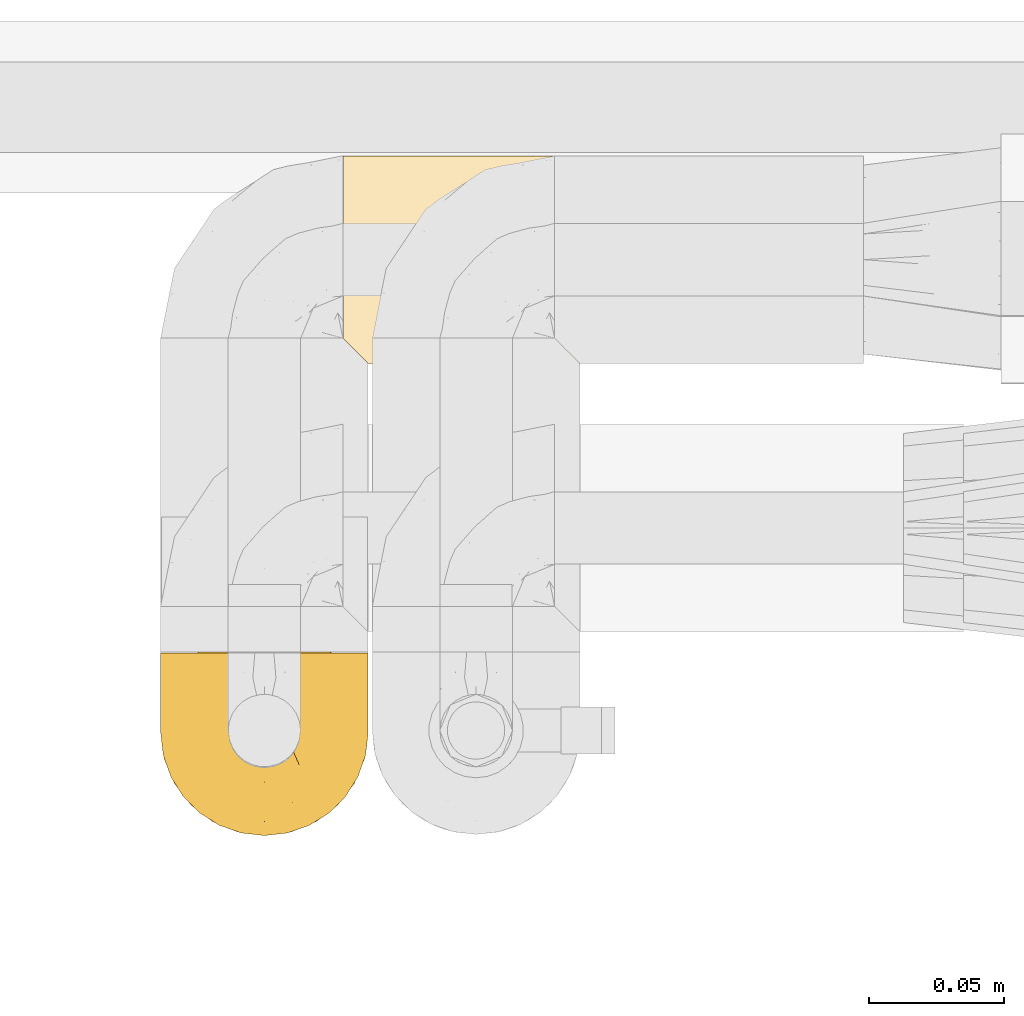
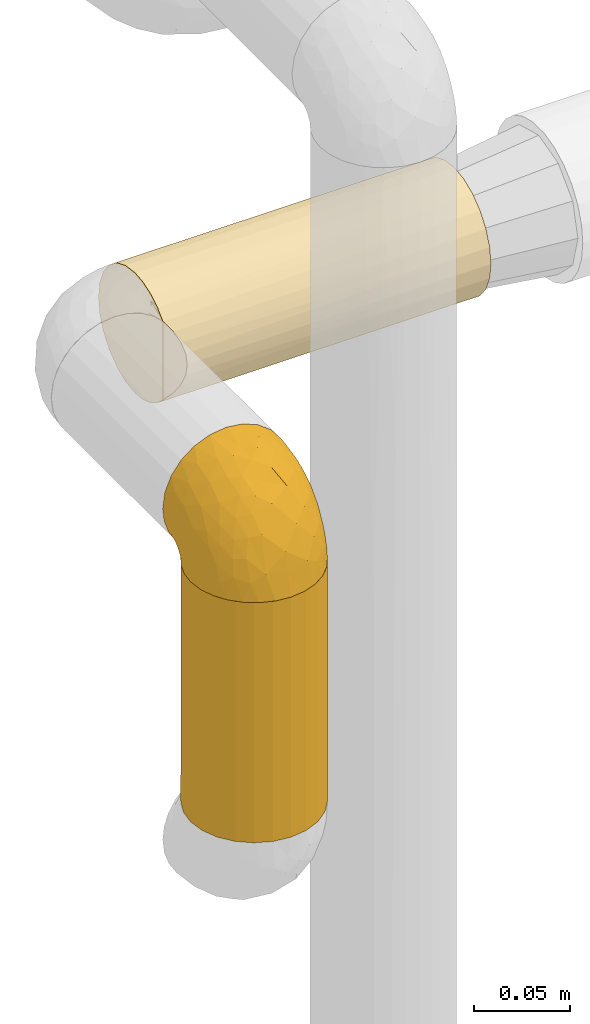
# One storey, part 469 of 827: 3 coverings.
"""IFC2X3 building model written with IfcOpenShell, lengths in millimetres."""

from ifc_helpers import new_model, entity, si_unit, converted_unit, derived_unit, direction, frame, origin, place, context, subcontext, project, spatial, faceted_brep, element, save


model = new_model("IFC2X3")

# Units and contexts
model_context = context("Model", 3, precision=0.01, world=origin(), true_north=direction((6.12303176911189e-17, 1.0)))
body_context = subcontext(model_context, "Body", "Model", "MODEL_VIEW")
ifc_project = project(units=[si_unit("LENGTHUNIT", "METRE", prefix="MILLI"), si_unit("AREAUNIT", "SQUARE_METRE"), si_unit("VOLUMEUNIT", "CUBIC_METRE"), converted_unit("PLANEANGLEUNIT", "DEGREE", entity("IfcRatioMeasure", 0.0174532925199433), si_unit("PLANEANGLEUNIT", "RADIAN"), dimensions=[0, 0, 0, 0, 0, 0, 0]), si_unit("MASSUNIT", "GRAM", prefix="KILO"), derived_unit("MASSDENSITYUNIT", [(si_unit("MASSUNIT", "GRAM", prefix="KILO"), 1), (si_unit("LENGTHUNIT", "METRE"), -3)]), derived_unit("MOMENTOFINERTIAUNIT", [(si_unit("LENGTHUNIT", "METRE"), 4)]), si_unit("TIMEUNIT", "SECOND"), si_unit("FREQUENCYUNIT", "HERTZ"), si_unit("THERMODYNAMICTEMPERATUREUNIT", "DEGREE_CELSIUS"), derived_unit("THERMALTRANSMITTANCEUNIT", [(si_unit("MASSUNIT", "GRAM", prefix="KILO"), 1), (si_unit("THERMODYNAMICTEMPERATUREUNIT", "KELVIN"), -1), (si_unit("TIMEUNIT", "SECOND"), -3)]), derived_unit("VOLUMETRICFLOWRATEUNIT", [(si_unit("LENGTHUNIT", "METRE"), 3), (si_unit("TIMEUNIT", "SECOND"), -1)]), derived_unit("MASSFLOWRATEUNIT", [(si_unit("MASSUNIT", "GRAM", prefix="KILO"), 1), (si_unit("TIMEUNIT", "SECOND"), -1)]), derived_unit("ROTATIONALFREQUENCYUNIT", [(si_unit("TIMEUNIT", "SECOND"), -1)]), si_unit("ELECTRICCURRENTUNIT", "AMPERE"), si_unit("ELECTRICVOLTAGEUNIT", "VOLT"), si_unit("POWERUNIT", "WATT"), si_unit("FORCEUNIT", "NEWTON", prefix="KILO"), si_unit("ILLUMINANCEUNIT", "LUX"), si_unit("LUMINOUSFLUXUNIT", "LUMEN"), si_unit("LUMINOUSINTENSITYUNIT", "CANDELA"), derived_unit("USERDEFINED", [(si_unit("MASSUNIT", "GRAM", prefix="KILO"), -1), (si_unit("LENGTHUNIT", "METRE"), -2), (si_unit("TIMEUNIT", "SECOND"), 3), (si_unit("LUMINOUSFLUXUNIT", "LUMEN"), 1)]), derived_unit("LINEARVELOCITYUNIT", [(si_unit("LENGTHUNIT", "METRE"), 1), (si_unit("TIMEUNIT", "SECOND"), -1)]), si_unit("PRESSUREUNIT", "PASCAL"), derived_unit("USERDEFINED", [(si_unit("LENGTHUNIT", "METRE"), -2), (si_unit("MASSUNIT", "GRAM", prefix="KILO"), 1), (si_unit("TIMEUNIT", "SECOND"), -2)]), derived_unit("LINEARFORCEUNIT", [(si_unit("MASSUNIT", "GRAM", prefix="KILO"), 1), (si_unit("LENGTHUNIT", "METRE"), 1), (si_unit("TIMEUNIT", "SECOND"), -2), (si_unit("LENGTHUNIT", "METRE"), -1)]), derived_unit("PLANARFORCEUNIT", [(si_unit("MASSUNIT", "GRAM", prefix="KILO"), 1), (si_unit("LENGTHUNIT", "METRE"), 1), (si_unit("TIMEUNIT", "SECOND"), -2), (si_unit("LENGTHUNIT", "METRE"), -2)])], contexts=[model_context])

# Site, building, storey
site_placement = place(None, origin())
site = spatial("IfcSite", under=ifc_project, at=site_placement, CompositionType="ELEMENT")
building_placement = place(site_placement, origin())
building = spatial("IfcBuilding", under=site, at=building_placement, CompositionType="ELEMENT")
storey_placement = place(building_placement, frame((0.0, 0.0, 28200.0)))
storey = spatial("IfcBuildingStorey", under=building, at=storey_placement, Name="08", CompositionType="ELEMENT", Elevation=28200.0)

# Coverings
covering_1_placement = place(storey_placement, frame((58451.15, 16264.34, 969.3)))
element("IfcCovering", 1, at=covering_1_placement, inside=storey, Name=":ADSK_", ObjectType=":ADSK_", PredefinedType="INSULATION", context=body_context, shape_type="Brep", body=[
    faceted_brep([(74.68, 23.36, 1.6), (70.1, 16.07, 1.6), (64.01, 9.98, 1.6), (56.72, 5.4, 1.6), (48.6, 2.56, 1.6), (40.05, 1.6, 1.6), (31.49, 2.56, 1.6), (23.36, 5.41, 1.6), (16.07, 9.99, 1.6), (9.98, 16.08, 1.6), (5.4, 23.37, 1.6), (2.56, 31.49, 1.6), (1.6, 40.05, 1.6), (2.46, 48.15, 1.6), (5.01, 55.88, 1.6), (9.13, 62.9, 1.6), (14.62, 68.89, 1.6), (16.82, 68.89, 1.6), (18.56, 68.89, 1.6), (20.52, 68.89, 1.6), (22.49, 68.89, 1.6), (24.46, 68.89, 1.6), (26.42, 68.89, 1.6), (28.39, 68.89, 1.6), (30.36, 68.89, 1.6), (32.55, 68.89, 1.6), (34.75, 68.89, 1.6), (36.94, 68.89, 1.6), (39.13, 68.89, 1.6), (41.33, 68.89, 1.6), (43.52, 68.89, 1.6), (45.72, 68.89, 1.6), (47.91, 68.89, 1.6), (50.11, 68.89, 1.6), (52.3, 68.89, 1.6), (54.49, 68.89, 1.6), (56.69, 68.89, 1.6), (58.88, 68.89, 1.6), (61.08, 68.89, 1.6), (63.27, 68.89, 1.6), (65.47, 68.89, 1.6), (70.97, 62.89, 1.6), (75.09, 55.86, 1.6), (77.64, 48.13, 1.6), (78.5, 40.05, 1.6), (77.53, 31.49, 1.6), (14.62, 69.15, 1.85), (9.12, 69.15, 7.85), (5.0, 69.15, 14.87), (2.46, 69.15, 22.6), (1.6, 69.15, 30.7), (2.91, 69.15, 40.65), (6.75, 69.15, 49.92), (12.86, 69.15, 57.88), (20.82, 69.15, 63.99), (30.09, 69.15, 67.84), (40.05, 69.15, 69.15), (50.0, 69.15, 67.84), (59.27, 69.15, 63.99), (67.23, 69.15, 57.88), (73.34, 69.15, 49.92), (77.19, 69.15, 40.65), (78.5, 69.15, 30.7), (77.63, 69.15, 22.6), (75.09, 69.15, 14.87), (70.97, 69.15, 7.85), (65.47, 69.15, 1.85), (63.27, 69.15, 1.85), (62.29, 69.15, 1.85), (60.7, 69.15, 1.85), (59.11, 69.15, 1.85), (57.52, 69.15, 1.85), (55.93, 69.15, 1.85), (54.34, 69.15, 1.85), (52.76, 69.15, 1.85), (51.17, 69.15, 1.85), (49.58, 69.15, 1.85), (47.99, 69.15, 1.85), (46.4, 69.15, 1.85), (44.81, 69.15, 1.85), (43.22, 69.15, 1.85), (41.63, 69.15, 1.85), (40.05, 69.15, 1.85), (38.46, 69.15, 1.85), (36.87, 69.15, 1.85), (35.28, 69.15, 1.85), (33.69, 69.15, 1.85), (32.1, 69.15, 1.85), (30.51, 69.15, 1.85), (28.92, 69.15, 1.85), (27.33, 69.15, 1.85), (25.37, 69.15, 1.85), (23.4, 69.15, 1.85), (21.21, 69.15, 1.85), (19.01, 69.15, 1.85), (16.82, 69.15, 1.85), (42.32, 68.96, 1.77), (44.02, 68.97, 1.78), (47.13, 68.97, 1.77), (48.74, 68.97, 1.77), (23.57, 68.95, 1.76), (25.13, 68.96, 1.77), (61.34, 68.98, 1.79), (22.02, 68.97, 1.78), (29.72, 68.97, 1.78), (56.73, 68.98, 1.78), (55.14, 68.97, 1.78), (37.66, 68.97, 1.78), (64.12, 68.94, 1.74), (28.13, 68.98, 1.78), (26.62, 68.98, 1.78), (31.46, 68.96, 1.77), (16.16, 68.97, 1.78), (39.16, 68.98, 1.78), (50.37, 68.98, 1.78), (17.69, 68.97, 1.77), (19.17, 68.96, 1.77), (62.78, 68.97, 1.77), (58.35, 68.97, 1.78), (45.53, 68.98, 1.78), (59.91, 68.96, 1.77), (65.47, 68.97, 1.77), (65.47, 68.94, 1.72), (65.47, 68.92, 1.66), (14.62, 68.97, 1.77), (14.62, 69.02, 1.8), (14.62, 69.08, 1.82), (20.59, 68.98, 1.79), (32.99, 68.97, 1.78), (34.48, 68.98, 1.79), (51.91, 68.97, 1.78), (65.47, 69.08, 1.82), (65.47, 69.02, 1.8), (53.48, 68.96, 1.76), (14.62, 68.92, 1.66), (14.62, 68.94, 1.72), (40.77, 68.97, 1.78), (35.97, 68.96, 1.77), (7.84, 67.02, 9.41), (3.53, 63.33, 17.65), (8.32, 64.61, 7.41), (1.6, 49.27, 21.47), (2.19, 51.4, 15.21), (1.6, 43.94, 16.15), (1.6, 61.87, 28.75), (4.57, 61.54, 13.67), (3.96, 57.95, 12.79), (2.28, 56.12, 19.18), (1.6, 63.4, 29.16), (7.69, 65.41, 9.04), (3.53, 53.1, 7.41), (8.32, 63.04, 5.74), (7.84, 61.33, 3.72), (1.6, 41.99, 8.87), (1.6, 54.6, 26.8), (4.34, 56.6, 9.53), (1.6, 41.58, 7.34), (29.63, 13.72, 37.63), (27.34, 5.82, 17.92), (40.05, 6.74, 27.45), (2.39, 58.82, 37.01), (2.43, 51.58, 34.22), (9.07, 42.09, 45.87), (16.64, 46.12, 56.57), (9.54, 55.56, 52.31), (4.52, 52.38, 42.07), (4.52, 61.54, 44.74), (7.49, 23.76, 21.49), (7.49, 20.5, 11.02), (12.85, 14.64, 15.64), (2.35, 41.77, 26.02), (22.66, 16.28, 36.59), (32.9, 49.4, 65.49), (25.33, 52.34, 63.99), (40.05, 4.3, 15.2), (16.64, 58.67, 60.27), (19.99, 25.26, 45.25), (16.37, 20.17, 35.21), (3.26, 34.7, 22.52), (3.75, 28.67, 12.03), (19.58, 8.62, 13.32), (7.5, 33.37, 35.9), (4.04, 41.35, 33.87), (13.94, 17.15, 25.73), (19.58, 12.68, 26.34), (28.21, 21.47, 46.78), (24.75, 41.11, 59.54), (31.42, 37.53, 60.18), (26.2, 30.64, 53.93), (33.36, 26.66, 53.36), (40.05, 21.38, 49.36), (40.05, 14.06, 38.4), (40.05, 55.54, 66.44), (16.14, 35.17, 50.09), (12.85, 29.04, 41.08), (10.47, 24.34, 31.14), (6.49, 29.33, 28.19), (40.05, 43.3, 64.0), (40.05, 32.34, 56.68), (75.57, 57.75, 43.9), (47.37, 49.41, 65.46), (52.91, 27.85, 52.22), (50.46, 13.7, 37.61), (67.23, 14.63, 15.64), (60.5, 8.61, 13.31), (70.55, 48.85, 50.02), (63.45, 54.13, 59.28), (62.61, 37.84, 53.05), (72.6, 23.75, 21.48), (72.6, 20.49, 11.01), (76.34, 28.66, 12.03), (59.34, 20.83, 41.02), (77.76, 55.15, 35.39), (78.5, 54.6, 26.8), (78.5, 61.87, 28.75), (78.5, 41.58, 7.34), (53.16, 57.58, 65.81), (70.55, 59.91, 53.28), (48.88, 36.94, 59.8), (54.76, 45.72, 61.82), (52.74, 5.82, 17.91), (71.93, 37.91, 41.4), (75.79, 50.18, 40.48), (60.5, 12.67, 26.34), (77.86, 49.29, 31.68), (77.64, 42.64, 27.68), (78.5, 43.94, 16.15), (78.5, 49.27, 21.47), (67.23, 19.45, 28.05), (76.82, 34.7, 22.54), (78.5, 41.99, 8.87), (77.8, 62.29, 37.3), (67.23, 29.01, 41.07), (73.2, 31.47, 32.24), (67.66, 37.18, 47.4), (75.99, 43.45, 35.77), (76.57, 63.33, 17.65), (73.21, 67.23, 11.06), (71.93, 66.07, 8.55), (71.07, 65.22, 6.63), (75.09, 61.99, 12.77), (76.13, 57.95, 12.79), (76.57, 53.09, 7.41), (77.69, 56.84, 18.97), (72.26, 61.33, 3.72), (71.77, 63.06, 5.76), (77.9, 51.41, 15.21), (75.75, 56.61, 9.52)], [[[0, 1, 2, 3, 4, 5, 6, 7, 8, 9, 10, 11, 12, 13, 14, 15, 16, 17, 18, 19, 20, 21, 22, 23, 24, 25, 26, 27, 28, 29, 30, 31, 32, 33, 34, 35, 36, 37, 38, 39, 40, 41, 42, 43, 44, 45]], [[46, 47, 48, 49, 50, 51, 52, 53, 54, 55, 56, 57, 58, 59, 60, 61, 62, 63, 64, 65, 66, 67, 68, 69, 70, 71, 72, 73, 74, 75, 76, 77, 78, 79, 80, 81, 82, 83, 84, 85, 86, 87, 88, 89, 90, 91, 92, 93, 94, 95]], [[96, 97, 30]], [[98, 77, 99]], [[100, 101, 21]], [[69, 68, 102]], [[20, 19, 103]], [[24, 23, 104]], [[20, 103, 100]], [[72, 105, 106]], [[84, 83, 107]], [[89, 88, 104]], [[108, 67, 66]], [[109, 110, 90]], [[111, 25, 24]], [[112, 17, 16]], [[82, 113, 83]], [[109, 23, 22]], [[114, 76, 75]], [[105, 36, 106]], [[104, 111, 24]], [[18, 115, 116]], [[97, 96, 80]], [[67, 108, 117]], [[105, 71, 118]], [[31, 97, 119]], [[102, 120, 69]], [[108, 121, 122, 123, 40]], [[112, 95, 115]], [[17, 115, 18]], [[94, 116, 115]], [[117, 68, 67]], [[38, 117, 39]], [[112, 124, 125, 126, 46]], [[17, 112, 115]], [[70, 120, 118]], [[39, 117, 108]], [[120, 38, 37]], [[120, 37, 118]], [[120, 70, 69]], [[116, 94, 127]], [[128, 86, 129]], [[117, 38, 102]], [[74, 130, 75]], [[99, 33, 32]], [[115, 95, 94]], [[39, 108, 40]], [[108, 66, 131, 132, 121]], [[105, 72, 71]], [[118, 37, 36]], [[71, 70, 118]], [[35, 106, 36]], [[36, 105, 118]], [[35, 133, 106]], [[74, 73, 133]], [[106, 133, 73]], [[99, 114, 33]], [[133, 35, 34]], [[73, 72, 106]], [[95, 112, 46]], [[112, 16, 134, 135, 124]], [[130, 114, 75]], [[99, 76, 114]], [[114, 130, 33]], [[34, 33, 130]], [[78, 77, 98]], [[98, 119, 78]], [[130, 133, 34]], [[133, 130, 74]], [[79, 97, 80]], [[98, 99, 32]], [[98, 32, 31]], [[77, 76, 99]], [[97, 79, 119]], [[136, 96, 29]], [[30, 97, 31]], [[136, 29, 28]], [[81, 80, 96]], [[29, 96, 30]], [[31, 119, 98]], [[119, 79, 78]], [[96, 136, 81]], [[82, 81, 136]], [[113, 107, 83]], [[84, 107, 137]], [[107, 27, 137]], [[113, 28, 107]], [[27, 107, 28]], [[85, 84, 137]], [[137, 27, 26]], [[113, 136, 28]], [[136, 113, 82]], [[109, 89, 104]], [[86, 85, 129]], [[89, 109, 90]], [[111, 87, 128]], [[26, 129, 137]], [[88, 111, 104]], [[25, 111, 128]], [[22, 110, 109]], [[23, 109, 104]], [[110, 91, 90]], [[100, 92, 101]], [[110, 22, 101]], [[91, 110, 101]], [[116, 19, 18]], [[111, 88, 87]], [[127, 103, 19]], [[25, 128, 26]], [[86, 128, 87]], [[128, 129, 26]], [[137, 129, 85]], [[120, 102, 38]], [[117, 102, 68]], [[91, 101, 92]], [[21, 101, 22]], [[93, 92, 103]], [[100, 21, 20]], [[100, 103, 92]], [[127, 93, 103]], [[93, 127, 94]], [[116, 127, 19]], [[126, 138, 47]], [[48, 138, 139]], [[140, 125, 124]], [[141, 142, 143]], [[144, 49, 139]], [[145, 140, 146]], [[48, 139, 49]], [[139, 145, 147]], [[49, 144, 148, 50]], [[126, 125, 149]], [[14, 13, 150]], [[151, 146, 140]], [[149, 140, 145]], [[152, 151, 135]], [[152, 14, 150]], [[16, 15, 134]], [[13, 153, 150]], [[124, 151, 140]], [[141, 147, 142]], [[14, 152, 15]], [[15, 152, 134]], [[47, 46, 126]], [[139, 154, 144]], [[138, 48, 47]], [[125, 140, 149]], [[135, 134, 152]], [[146, 155, 142]], [[145, 146, 147]], [[149, 139, 138]], [[147, 141, 154]], [[147, 146, 142]], [[139, 147, 154]], [[139, 149, 145]], [[149, 138, 126]], [[155, 146, 151]], [[150, 143, 142]], [[152, 155, 151]], [[150, 142, 155]], [[13, 12, 156, 153]], [[153, 143, 150]], [[152, 150, 155]], [[151, 124, 135]], [[157, 158, 159]], [[160, 154, 161]], [[162, 163, 164]], [[165, 166, 160]], [[167, 168, 169]], [[141, 170, 161]], [[156, 12, 11]], [[158, 157, 171]], [[172, 55, 173]], [[158, 6, 174]], [[175, 54, 53]], [[52, 166, 164]], [[52, 164, 53]], [[54, 175, 173]], [[166, 52, 51]], [[176, 177, 171]], [[178, 143, 179]], [[156, 11, 179]], [[8, 7, 180]], [[169, 9, 8]], [[179, 143, 153, 156]], [[179, 11, 10]], [[168, 179, 10]], [[181, 162, 182]], [[179, 167, 178]], [[183, 184, 177]], [[183, 169, 184]], [[176, 171, 185]], [[172, 186, 187]], [[158, 7, 6]], [[159, 158, 174]], [[184, 180, 158]], [[54, 173, 55]], [[180, 169, 8]], [[188, 189, 187]], [[9, 168, 10]], [[186, 188, 187]], [[190, 157, 159, 191]], [[55, 172, 192]], [[176, 193, 194]], [[161, 170, 182]], [[162, 164, 165]], [[175, 164, 163]], [[51, 50, 148]], [[167, 195, 196]], [[178, 182, 170]], [[6, 5, 174]], [[158, 180, 7]], [[169, 180, 184]], [[169, 168, 9]], [[179, 168, 167]], [[182, 162, 165]], [[162, 194, 193]], [[161, 165, 160]], [[195, 181, 196]], [[192, 172, 197]], [[192, 56, 55]], [[189, 190, 198]], [[198, 197, 187]], [[172, 187, 197]], [[185, 189, 188]], [[198, 187, 189]], [[186, 172, 173]], [[173, 163, 186]], [[193, 186, 163]], [[176, 185, 188]], [[185, 157, 190]], [[188, 186, 193]], [[177, 176, 194]], [[188, 193, 176]], [[162, 193, 163]], [[195, 177, 194]], [[171, 177, 184]], [[181, 195, 194]], [[183, 167, 169]], [[162, 181, 194]], [[196, 182, 178]], [[158, 171, 184]], [[171, 157, 185]], [[177, 195, 183]], [[167, 183, 195]], [[182, 196, 181]], [[178, 170, 143]], [[178, 167, 196]], [[164, 175, 53]], [[173, 175, 163]], [[160, 51, 148]], [[164, 166, 165]], [[51, 160, 166]], [[160, 148, 144, 154]], [[141, 161, 154]], [[182, 165, 161]], [[190, 189, 185]], [[143, 170, 141]], [[60, 199, 61]], [[197, 200, 192]], [[201, 190, 202]], [[200, 57, 192]], [[203, 204, 2]], [[205, 206, 207]], [[208, 209, 210]], [[211, 207, 201]], [[212, 213, 214]], [[45, 215, 210]], [[216, 206, 58]], [[45, 44, 215]], [[59, 217, 60]], [[60, 217, 199]], [[0, 45, 210]], [[218, 201, 219]], [[202, 159, 220]], [[205, 221, 222]], [[223, 204, 203]], [[1, 203, 2]], [[57, 200, 216]], [[220, 3, 204]], [[220, 174, 4]], [[1, 0, 209]], [[212, 224, 213]], [[225, 226, 227]], [[228, 223, 203]], [[208, 210, 229]], [[210, 226, 229]], [[3, 220, 4]], [[58, 206, 59]], [[209, 203, 1]], [[202, 220, 223]], [[228, 203, 208]], [[202, 211, 201]], [[3, 2, 204]], [[202, 190, 191, 159]], [[210, 215, 230, 226]], [[199, 212, 231]], [[232, 233, 221]], [[233, 208, 229]], [[207, 206, 219]], [[217, 206, 205]], [[227, 224, 225]], [[233, 232, 228]], [[201, 207, 219]], [[234, 232, 221]], [[218, 219, 200]], [[202, 223, 211]], [[174, 220, 159]], [[174, 5, 4]], [[61, 231, 62]], [[220, 204, 223]], [[210, 209, 0]], [[203, 209, 208]], [[225, 233, 229]], [[224, 227, 213]], [[221, 233, 235]], [[57, 56, 192]], [[198, 218, 197]], [[200, 219, 216]], [[201, 198, 190]], [[197, 218, 200]], [[198, 201, 218]], [[206, 216, 219]], [[58, 57, 216]], [[231, 212, 214]], [[222, 212, 199]], [[228, 211, 223]], [[207, 211, 232]], [[62, 231, 214]], [[199, 231, 61]], [[233, 228, 208]], [[211, 228, 232]], [[222, 221, 235]], [[234, 205, 207]], [[206, 217, 59]], [[199, 217, 205]], [[205, 222, 199]], [[224, 222, 235]], [[222, 224, 212]], [[224, 235, 225]], [[233, 225, 235]], [[226, 225, 229]], [[205, 234, 221]], [[207, 232, 234]], [[63, 214, 236]], [[214, 213, 236]], [[214, 63, 62]], [[237, 236, 238]], [[238, 132, 131]], [[236, 237, 64]], [[239, 240, 241]], [[63, 236, 64]], [[131, 66, 65]], [[237, 131, 65]], [[242, 230, 43]], [[237, 65, 64]], [[239, 121, 132]], [[42, 242, 43]], [[241, 240, 243]], [[41, 123, 244]], [[43, 230, 215, 44]], [[244, 122, 245]], [[227, 246, 243]], [[241, 247, 245]], [[121, 239, 245]], [[41, 40, 123]], [[132, 238, 239]], [[244, 42, 41]], [[131, 237, 238]], [[240, 239, 238]], [[245, 239, 241]], [[247, 241, 246]], [[247, 244, 245]], [[238, 236, 240]], [[243, 236, 213]], [[236, 243, 240]], [[227, 226, 246]], [[243, 213, 227]], [[242, 246, 226]], [[243, 246, 241]], [[246, 242, 247]], [[244, 247, 242]], [[242, 226, 230]], [[42, 244, 242]], [[122, 244, 123]], [[122, 121, 245]]]),
])
covering_2_placement = place(storey_placement, frame((58451.2, 16264.39, 817.55)))
element("IfcCovering", 2, at=covering_2_placement, inside=storey, Name=":ADSK_", ObjectType=":ADSK_", PredefinedType="INSULATION", context=body_context, shape_type="Brep", body=[
    faceted_brep([(73.25, 20.8, 153.35), (77.09, 30.06, 153.35), (78.4, 40.0, 153.35), (77.51, 48.2, 153.35), (74.9, 56.01, 153.35), (70.68, 63.08, 153.35), (65.05, 69.1, 153.35), (14.94, 69.1, 153.35), (9.31, 63.08, 153.35), (5.09, 56.01, 153.35), (2.48, 48.2, 153.35), (1.6, 40.0, 153.35), (2.9, 30.06, 153.35), (6.74, 20.8, 153.35), (12.84, 12.84, 153.35), (20.8, 6.74, 153.35), (30.06, 2.9, 153.35), (40.0, 1.6, 153.35), (49.93, 2.9, 153.35), (59.2, 6.74, 153.35), (67.15, 12.84, 153.35), (73.25, 20.8, 0.0), (67.15, 12.84, 0.0), (59.2, 6.74, 0.0), (49.93, 2.9, 0.0), (40.0, 1.6, 0.0), (30.06, 2.9, 0.0), (20.8, 6.74, 0.0), (12.84, 12.84, 0.0), (6.74, 20.8, 0.0), (2.9, 30.06, 0.0), (1.6, 40.0, 0.0), (2.9, 49.93, 0.0), (6.74, 59.2, 0.0), (12.84, 67.15, 0.0), (20.8, 73.25, 0.0), (30.06, 77.09, 0.0), (40.0, 78.4, 0.0), (49.93, 77.09, 0.0), (59.2, 73.25, 0.0), (67.15, 67.15, 0.0), (73.25, 59.2, 0.0), (77.09, 49.93, 0.0), (78.4, 40.0, 0.0), (77.09, 30.06, 0.0), (33.21, 77.79, 144.65), (40.0, 78.4, 144.05), (26.63, 76.0, 146.45), (20.48, 73.07, 149.37), (53.36, 76.0, 146.45), (46.78, 77.79, 144.65), (59.51, 73.07, 149.37)], [[[0, 1, 2, 3, 4, 5, 6, 7, 8, 9, 10, 11, 12, 13, 14, 15, 16, 17, 18, 19, 20]], [[21, 22, 23, 24, 25, 26, 27, 28, 29, 30, 31, 32, 33, 34, 35, 36, 37, 38, 39, 40, 41, 42, 43, 44]], [[45, 46, 37]], [[45, 37, 36]], [[47, 36, 35]], [[47, 45, 36]], [[7, 48, 35]], [[47, 35, 48]], [[35, 34, 7]], [[8, 34, 33]], [[9, 33, 32]], [[10, 32, 31]], [[8, 33, 9]], [[9, 32, 10]], [[31, 11, 10]], [[34, 8, 7]], [[12, 11, 31, 30]], [[13, 12, 30, 29]], [[29, 28, 14, 13]], [[16, 15, 27, 26]], [[17, 16, 26, 25]], [[28, 27, 15, 14]], [[18, 17, 25, 24]], [[19, 18, 24, 23]], [[23, 22, 20, 19]], [[1, 0, 21, 44]], [[2, 1, 44, 43]], [[22, 21, 0, 20]], [[3, 43, 42]], [[4, 42, 41]], [[5, 41, 40]], [[2, 43, 3]], [[3, 42, 4]], [[41, 5, 4]], [[40, 6, 5]], [[49, 39, 38]], [[38, 37, 50]], [[46, 50, 37]], [[51, 6, 39]], [[50, 49, 38]], [[51, 39, 49]], [[39, 6, 40]], [[49, 50, 46, 45, 47, 48, 7, 6, 51]]]),
])
covering_3_placement = place(storey_placement, frame((58518.69, 16439.19, 960.0)))
element("IfcCovering", 3, at=covering_3_placement, inside=storey, Name=":ADSK_", ObjectType=":ADSK_", PredefinedType="INSULATION", context=body_context, shape_type="Brep", body=[
    faceted_brep([(1.6, 24.02, 5.09), (1.6, 16.95, 9.31), (1.6, 10.93, 14.93), (1.6, 10.93, 65.06), (1.6, 16.95, 70.68), (1.6, 24.02, 74.9), (1.6, 31.83, 77.51), (1.6, 40.03, 78.4), (1.6, 49.97, 77.09), (1.6, 59.23, 73.25), (1.6, 67.18, 67.15), (1.61, 73.28, 59.2), (1.61, 77.12, 49.93), (1.61, 78.43, 40.0), (1.61, 77.12, 30.06), (1.61, 73.28, 20.8), (1.6, 67.18, 12.84), (1.6, 59.23, 6.74), (1.6, 49.97, 2.9), (1.6, 40.03, 1.6), (1.6, 31.83, 2.48), (194.32, 2.9, 30.06), (194.32, 6.74, 20.8), (194.32, 12.84, 12.84), (194.32, 20.8, 6.74), (194.32, 30.06, 2.9), (194.33, 40.0, 1.6), (194.33, 49.93, 2.9), (194.33, 59.2, 6.74), (194.33, 67.15, 12.84), (194.33, 73.25, 20.8), (194.33, 77.09, 30.06), (194.33, 78.4, 40.0), (194.33, 77.09, 49.93), (194.33, 73.25, 59.2), (194.33, 67.15, 67.15), (194.33, 59.2, 73.25), (194.33, 49.93, 77.09), (194.33, 40.0, 78.4), (194.32, 30.06, 77.09), (194.32, 20.8, 73.25), (194.32, 12.84, 67.15), (194.32, 6.74, 59.2), (194.32, 2.9, 49.93), (194.32, 1.6, 40.0), (8.5, 4.03, 26.63), (10.3, 2.23, 33.21), (10.9, 1.63, 40.0), (5.57, 6.96, 20.47), (10.3, 2.23, 46.79), (8.5, 4.03, 53.36), (5.57, 6.96, 59.52)], [[[0, 1, 2, 3, 4, 5, 6, 7, 8, 9, 10, 11, 12, 13, 14, 15, 16, 17, 18, 19, 20]], [[21, 22, 23, 24, 25, 26, 27, 28, 29, 30, 31, 32, 33, 34, 35, 36, 37, 38, 39, 40, 41, 42, 43, 44]], [[31, 30, 15, 14]], [[32, 31, 14, 13]], [[30, 29, 16, 15]], [[18, 17, 28, 27]], [[19, 18, 27, 26]], [[29, 28, 17, 16]], [[20, 26, 25]], [[0, 25, 24]], [[1, 24, 23]], [[19, 26, 20]], [[20, 25, 0]], [[24, 1, 0]], [[23, 2, 1]], [[45, 22, 21]], [[21, 44, 46]], [[47, 46, 44]], [[48, 2, 22]], [[46, 45, 21]], [[48, 22, 45]], [[22, 2, 23]], [[49, 47, 44]], [[49, 44, 43]], [[50, 43, 42]], [[50, 49, 43]], [[3, 51, 42]], [[50, 42, 51]], [[42, 41, 3]], [[4, 41, 40]], [[5, 40, 39]], [[6, 39, 38]], [[4, 40, 5]], [[5, 39, 6]], [[38, 7, 6]], [[41, 4, 3]], [[8, 7, 38, 37]], [[9, 8, 37, 36]], [[36, 35, 10, 9]], [[12, 11, 34, 33]], [[13, 12, 33, 32]], [[35, 34, 11, 10]], [[2, 48, 45, 46, 47, 49, 50, 51, 3]]]),
])

save(model, "model.ifc")
